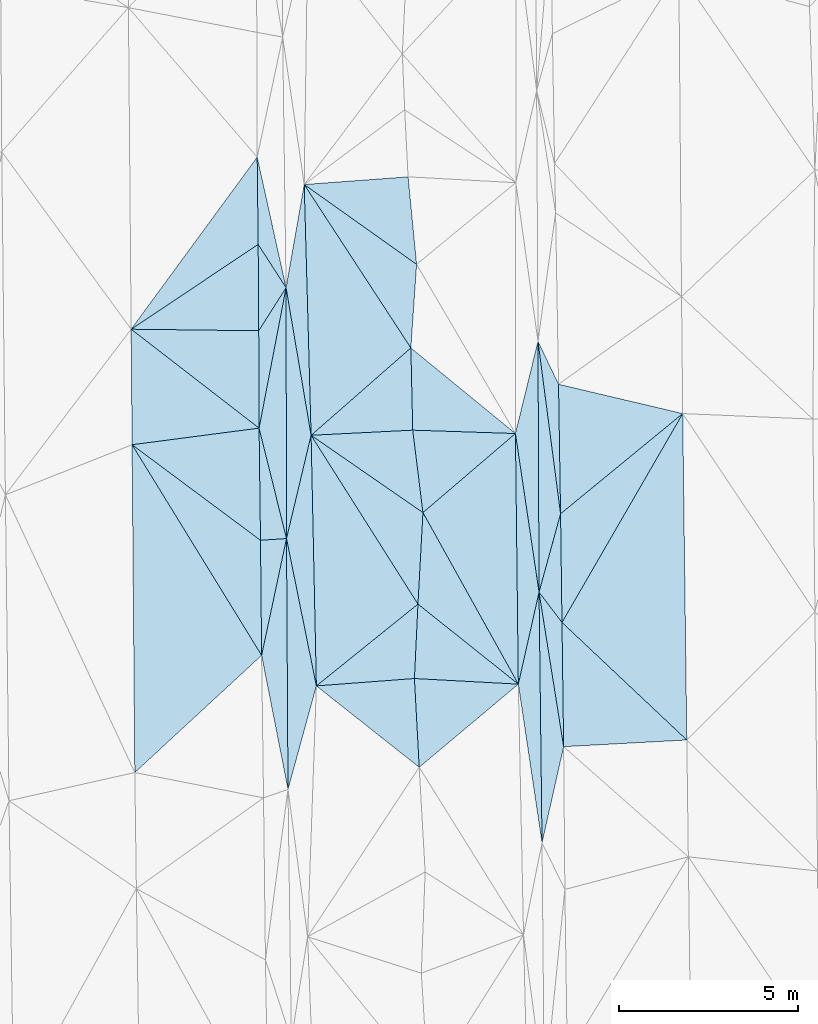
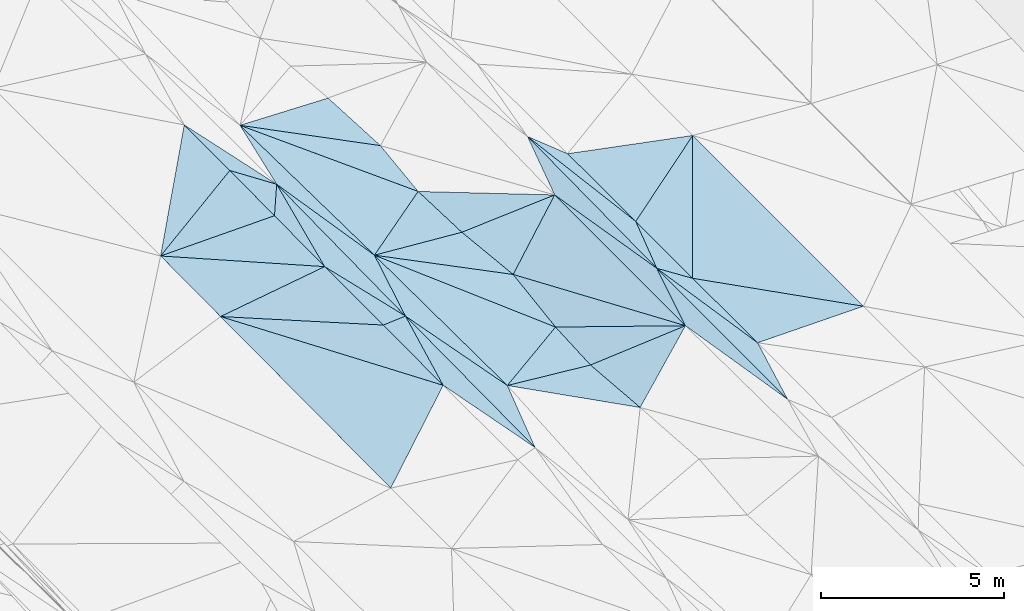
# One storey, part 35 of 275: 45 plates.
"""IFC2X3 building model written with IfcOpenShell, lengths in millimetres."""

import ifcopenshell
import ifcopenshell.guid

model = None  # the IFC model being written
_history = None  # IfcOwnerHistory: only IFC2X3 demands one
_inside = {}  # id of a spatial element -> (the spatial element, [elements in it])
_under = {}  # id of a project, library or spatial element -> (it, [spatial elements below it])
_declared = {}  # id of a project -> (the project, [libraries it declares])
_typed = {}  # id of a type object -> (the type object, [elements of that type])
_made_of = {}  # id of a material, layer set ... -> (it, [elements and type objects made of it])


def new_model(schema):
    """Start an empty IFC model of exactly this schema.

    Asked for "IFC4X3", IfcOpenShell would pick the latest addendum, in which some entities
    have other attributes; the version numbers below select the first issue.
    IFC2X3 requires an IfcOwnerHistory on every rooted entity: one is made here for all.
    """
    global model, _history
    if schema == "IFC4X3":
        model = ifcopenshell.file(schema_version=(4, 3, 0, 0))
    else:
        model = ifcopenshell.file(schema=schema)
    _inside.clear()
    _under.clear()
    _declared.clear()
    _typed.clear()
    _made_of.clear()
    _history = None
    if model.schema == "IFC2X3":
        org = make("IfcOrganization", Name="unknown")
        user = make(
            "IfcPersonAndOrganization",
            ThePerson=make("IfcPerson", FamilyName="unknown"),
            TheOrganization=org,
        )
        app = make(
            "IfcApplication",
            ApplicationDeveloper=org,
            Version="unknown",
            ApplicationFullName="unknown",
            ApplicationIdentifier="unknown",
        )
        _history = make(
            "IfcOwnerHistory",
            OwningUser=user,
            OwningApplication=app,
            ChangeAction="ADDED",
            CreationDate=0,
        )
    return model


def make(cls, **values):
    """One entity of the class cls with the attributes given. An attribute that is None is left unset."""
    return model.create_entity(
        cls, **{name: value for name, value in values.items() if value is not None}
    )


def rooted(cls, **values):
    """An entity with a GlobalId (a new one), such as an element, a storey or a relation."""
    return make(cls, GlobalId=ifcopenshell.guid.new(), OwnerHistory=_history, **values)


def si_unit(unit_type, name, prefix=None):
    """IfcSIUnit, for example si_unit("LENGTHUNIT", "METRE", prefix="MILLI")."""
    return make("IfcSIUnit", UnitType=unit_type, Prefix=prefix, Name=name)


def assignment(units):
    """IfcUnitAssignment: the units of a project."""
    return None if units is None else make("IfcUnitAssignment", Units=units)


def point(xyz):
    """IfcCartesianPoint."""
    return None if xyz is None else make("IfcCartesianPoint", Coordinates=xyz)


def direction(xyz):
    """IfcDirection."""
    return None if xyz is None else make("IfcDirection", DirectionRatios=xyz)


def frame(location, z_axis=None, x_axis=None):
    """IfcAxis2Placement3D, a coordinate frame: its origin and axes. An axis left out is left unset."""
    return make(
        "IfcAxis2Placement3D",
        Location=point(location),
        Axis=direction(z_axis),
        RefDirection=direction(x_axis),
    )


def origin_with_axes():
    """The frame at (0, 0, 0) with the z axis (0, 0, 1) and the x axis (1, 0, 0) written out."""
    return frame((0.0, 0.0, 0.0), z_axis=(0.0, 0.0, 1.0), x_axis=(1.0, 0.0, 0.0))


def place(relative_to, where):
    """IfcLocalPlacement: puts the frame where relative to a parent placement (None: the world)."""
    return make(
        "IfcLocalPlacement", PlacementRelTo=relative_to, RelativePlacement=where
    )


def context(
    kind, dimensions, precision=None, world=None, true_north=None, identifier=None
):
    """IfcGeometricRepresentationContext, for example the 3D "Model" context."""
    return make(
        "IfcGeometricRepresentationContext",
        ContextIdentifier=identifier,
        ContextType=kind,
        CoordinateSpaceDimension=dimensions,
        Precision=precision,
        WorldCoordinateSystem=world,
        TrueNorth=true_north,
    )


def subcontext(parent, identifier, kind, view, scale=None):
    """IfcGeometricRepresentationSubContext, for example "Body" below "Model"."""
    return make(
        "IfcGeometricRepresentationSubContext",
        ContextIdentifier=identifier,
        ContextType=kind,
        ParentContext=parent,
        TargetScale=scale,
        TargetView=view,
    )


def project(units=None, contexts=None):
    """IfcProject with its units and contexts."""
    return rooted(
        "IfcProject",
        Name="project",
        RepresentationContexts=contexts,
        UnitsInContext=assignment(units),
    )


def spatial(cls, under=None, at=None, **own):
    """A site, building, storey or space (cls), placed at a placement, below another one or the project."""
    s = rooted(cls, ObjectPlacement=at, **own)
    if under is not None:
        _under.setdefault(under.id(), (under, []))[1].append(s)
    return s


def polyline(points):
    """IfcPolyline through the points."""
    return make("IfcPolyline", Points=[point(p) for p in points])


def outline(outer, holes=None, kind="AREA"):
    """IfcArbitraryClosedProfileDef: a profile drawn as a closed curve; with holes, ...WithVoids."""
    if holes is None:
        return make("IfcArbitraryClosedProfileDef", ProfileType=kind, OuterCurve=outer)
    return make(
        "IfcArbitraryProfileDefWithVoids",
        ProfileType=kind,
        OuterCurve=outer,
        InnerCurves=holes,
    )


def extrude(swept, where, along, depth):
    """IfcExtrudedAreaSolid: the profile swept, set in the frame where, extruded along a direction by depth."""
    return make(
        "IfcExtrudedAreaSolid",
        SweptArea=swept,
        Position=where,
        ExtrudedDirection=direction(along),
        Depth=depth,
    )


def shape(context_of_items, identifier, shape_type, items):
    """IfcShapeRepresentation: the items that make up one representation, for example the "Body"."""
    return make(
        "IfcShapeRepresentation",
        ContextOfItems=context_of_items,
        RepresentationIdentifier=identifier,
        RepresentationType=shape_type,
        Items=items,
    )


def material(Name=None, Category=None):
    """IfcMaterial."""
    return make("IfcMaterial", Name=Name, Category=Category)


def made_of(thing, what):
    """Note that an element or type object is made of a material, layer set ...; save() writes the relation."""
    if what is not None:
        _made_of.setdefault(what.id(), (what, []))[1].append(thing)
    return thing


def type_object(cls, material=None, **own):
    """A type object (cls), such as IfcWallType, which elements share."""
    return made_of(rooted(cls, **own), material)


def element(
    cls,
    number,
    at=None,
    inside=None,
    cuts=None,
    type_object=None,
    material=None,
    context=None,
    identifier="Body",
    shape_type=None,
    held_by="IfcProductDefinitionShape",
    body=None,
    shapes=None,
    **own,
):
    """One element of the class cls, such as IfcWall. Its Tag is "e" and its number.

    at: its placement. inside: the storey or other place that contains it. cuts: it is an
    opening in that element (IfcRelVoidsElement). A single representation is given by context,
    identifier, shape_type and body (its items); several are given by shapes. held_by: the class
    of the entity that holds the representations. save() writes the other relations.
    """
    e = rooted(cls, Tag="e%d" % number, ObjectPlacement=at, **own)
    if body is not None:
        shapes = [shape(context, identifier, shape_type, body)]
    if shapes is not None:
        e.Representation = make(held_by, Representations=shapes)
    if inside is not None:
        _inside.setdefault(inside.id(), (inside, []))[1].append(e)
    if cuts is not None:
        rooted(
            "IfcRelVoidsElement", RelatingBuildingElement=cuts, RelatedOpeningElement=e
        )
    if type_object is not None:
        _typed.setdefault(type_object.id(), (type_object, []))[1].append(e)
    return made_of(e, material)


def aggregate(whole, parts):
    """IfcRelAggregates: a whole, such as a stair, and the parts it consists of."""
    return rooted("IfcRelAggregates", RelatingObject=whole, RelatedObjects=parts)


def save(model, path):
    """Write the relations noted so far, then the file.

    IfcRelAggregates (storeys below a building ...), IfcRelContainedInSpatialStructure (elements
    in a storey), IfcRelDefinesByType, IfcRelAssociatesMaterial and IfcRelDeclares: one each for
    every whole, place, type object, material and project.
    """
    for whole, parts in _under.values():
        aggregate(whole, parts)
    for where, things in _inside.values():
        rooted(
            "IfcRelContainedInSpatialStructure",
            RelatedElements=things,
            RelatingStructure=where,
        )
    for kind, things in _typed.values():
        rooted("IfcRelDefinesByType", RelatedObjects=things, RelatingType=kind)
    for what, things in _made_of.values():
        rooted("IfcRelAssociatesMaterial", RelatedObjects=things, RelatingMaterial=what)
    for by, libraries in _declared.values():
        rooted("IfcRelDeclares", RelatingContext=by, RelatedDefinitions=libraries)
    model.write(path)


model = new_model("IFC2X3")

# Units and contexts
model_context = context("Model", 3, precision=1e-05, world=origin_with_axes())
body_context = subcontext(model_context, "Body", "Model", "MODEL_VIEW")
ifc_project = project(units=[si_unit("LENGTHUNIT", "METRE", prefix="MILLI"), si_unit("AREAUNIT", "SQUARE_METRE"), si_unit("VOLUMEUNIT", "CUBIC_METRE"), si_unit("MASSUNIT", "GRAM", prefix="KILO"), si_unit("TIMEUNIT", "SECOND"), si_unit("PLANEANGLEUNIT", "RADIAN"), si_unit("SOLIDANGLEUNIT", "STERADIAN"), si_unit("THERMODYNAMICTEMPERATUREUNIT", "DEGREE_CELSIUS"), si_unit("LUMINOUSINTENSITYUNIT", "LUMEN")], contexts=[model_context])

# Site, building, storey
site_placement = place(None, origin_with_axes())
site = spatial("IfcSite", under=ifc_project, at=site_placement, CompositionType="ELEMENT")
building_placement = place(site_placement, origin_with_axes())
building = spatial("IfcBuilding", under=site, at=building_placement, Name="Undefined", CompositionType="ELEMENT")
storey_placement = place(building_placement, origin_with_axes())
storey = spatial("IfcBuildingStorey", under=building, at=storey_placement, Name="Undefined", CompositionType="ELEMENT", Elevation=0.0)

# Plates
ifc_material = material()
plate_type_1 = type_object("IfcPlateType", PredefinedType="NOTDEFINED")
plate_1_placement = place(storey_placement, frame((-83577.8954282212, 28888.7044978284, 41809.500438264), z_axis=(0.0365790890589435, 0.0219837496908715, -0.999088927469996), x_axis=(-0.00810992466042076, 0.999731612560137, 0.0217009670270915)))
element("IfcPlate", 1, at=plate_1_placement, inside=storey, type_object=plate_type_1, material=ifc_material, Name="00", context=body_context, shape_type="SweptSolid", body=[
    extrude(outline(polyline([(0.0, 0.0), (3225.66284179688, -7.8580342233181e-10), (437.305480957031, 3551.52978515625), (0.0, 0.0)])), frame((-8.85201319254618e-08, 2.18876761149539e-07, -0.5000001331573), z_axis=(0.0, 0.0, 1.0), x_axis=(1.0, 0.0, 0.0)), (0.0, 0.0, 1.0), 1.0),
])
plate_type_2 = type_object("IfcPlateType", PredefinedType="NOTDEFINED")
plate_2_placement = place(storey_placement, frame((-71531.1187401543, 20460.0011105152, 41829.5001680198), z_axis=(-0.0158859229955657, 0.0218092317217035, -0.999635931158083), x_axis=(-0.219018831395794, -0.975558195381278, -0.0178033400923545)))
element("IfcPlate", 2, at=plate_2_placement, inside=storey, type_object=plate_type_2, material=ifc_material, Name="00", context=body_context, shape_type="SweptSolid", body=[
    extrude(outline(polyline([(0.0, 0.0), (2752.29248046875, -6.37373887002468e-09), (-4058.8349609375, 1614.81384277344), (0.0, 0.0)])), frame((-8.85201319254618e-08, 2.18876761149539e-07, -0.5000001331573), z_axis=(0.0, 0.0, 1.0), x_axis=(1.0, 0.0, 0.0)), (0.0, 0.0, 1.0), 1.0),
])
plate_type_3 = type_object("IfcPlateType", PredefinedType="NOTDEFINED")
plate_3_placement = place(storey_placement, frame((-72217.5719747491, 24772.717407491, 41934.5006367606), z_axis=(-0.0482096767140328, 0.0166415767088893, -0.998698595671272), x_axis=(0.603394067693805, -0.796315346795605, -0.0423965509177359)))
element("IfcPlate", 3, at=plate_3_placement, inside=storey, type_object=plate_type_3, material=ifc_material, Name="00", context=body_context, shape_type="SweptSolid", body=[
    extrude(outline(polyline([(0.0, 0.0), (1061.40710449219, -2.30647856369615e-09), (3852.92797851563, 2058.32739257813), (0.0, 0.0)])), frame((-8.85201319254618e-08, 2.18876761149539e-07, -0.5000001331573), z_axis=(0.0, 0.0, 1.0), x_axis=(1.0, 0.0, 0.0)), (0.0, 0.0, 1.0), 1.0),
])
plate_4_placement = place(storey_placement, frame((-80085.5849594555, 36916.2971563782, 42099.5003578976), z_axis=(0.0323594222888337, 0.0208706576789451, -0.999258366708621), x_axis=(0.216025640668646, -0.976295798259957, -0.0133954049455226)))
element("IfcPlate", 4, at=plate_4_placement, inside=storey, type_object=plate_type_3, material=ifc_material, Name="00", context=body_context, shape_type="SweptSolid", body=[
    extrude(outline(polyline([(0.0, 0.0), (3732.62329101563, 1.23254721984267e-08), (2385.78051757813, 499.751312255859), (0.0, 0.0)])), frame((-8.85201319254618e-08, 2.18876761149539e-07, -0.5000001331573), z_axis=(0.0, 0.0, 1.0), x_axis=(1.0, 0.0, 0.0)), (0.0, 0.0, 1.0), 1.0),
])
plate_type_4 = type_object("IfcPlateType", PredefinedType="NOTDEFINED")
plate_5_placement = place(storey_placement, frame((-75562.7001384083, 19884.6849697928, 41435.504392064), z_axis=(0.132110338187401, -0.00929839405583627, -0.991191403520023), x_axis=(-0.0536836325164533, 0.998421309205957, -0.0165214080302371)))
element("IfcPlate", 5, at=plate_5_placement, inside=storey, type_object=plate_type_4, material=ifc_material, Name="00", context=body_context, shape_type="SweptSolid", body=[
    extrude(outline(polyline([(0.0, 0.0), (2481.62866210938, 1.71712599694729e-09), (2163.00415039063, 2912.6962890625), (0.0, 0.0)])), frame((-8.85201319254618e-08, 2.18876761149539e-07, -0.5000001331573), z_axis=(0.0, 0.0, 1.0), x_axis=(1.0, 0.0, 0.0)), (0.0, 0.0, 1.0), 1.0),
])
plate_type_5 = type_object("IfcPlateType", PredefinedType="NOTDEFINED")
plate_6_placement = place(storey_placement, frame((-78580.5815478131, 29151.8177160993, 41943.5003782891), z_axis=(-0.0342257553858647, 0.0199021579772941, -0.999215943515772), x_axis=(-0.167131835422519, 0.985608457515903, 0.0253558289436967)))
element("IfcPlate", 6, at=plate_6_placement, inside=storey, type_object=plate_type_5, material=ifc_material, Name="00", context=body_context, shape_type="SweptSolid", body=[
    extrude(outline(polyline([(0.0, 0.0), (4180.49853515625, 1.17870513349772e-09), (6935.2119140625, 981.620422363281), (0.0, 0.0)])), frame((-8.85201319254618e-08, 2.18876761149539e-07, -0.5000001331573), z_axis=(0.0, 0.0, 1.0), x_axis=(1.0, 0.0, 0.0)), (0.0, 0.0, 1.0), 1.0),
])
plate_type_6 = type_object("IfcPlateType", PredefinedType="NOTDEFINED")
plate_7_placement = place(storey_placement, frame((-71577.1213630307, 23927.5055979351, 41889.500522527), z_axis=(-0.0404609860858899, 0.0225251823164607, -0.998927186919331), x_axis=(-0.603394067694056, 0.796315346795313, 0.0423965509196396)))
element("IfcPlate", 7, at=plate_7_placement, inside=storey, type_object=plate_type_6, material=ifc_material, Name="00", context=body_context, shape_type="SweptSolid", body=[
    extrude(outline(polyline([(0.0, 0.0), (1061.40710449219, -2.30647856369615e-09), (2442.107421875, 1800.33654785156), (0.0, 0.0)])), frame((-8.85201319254618e-08, 2.18876761149539e-07, -0.5000001331573), z_axis=(0.0, 0.0, 1.0), x_axis=(1.0, 0.0, 0.0)), (0.0, 0.0, 1.0), 1.0),
])
plate_type_7 = type_object("IfcPlateType", PredefinedType="NOTDEFINED")
plate_8_placement = place(storey_placement, frame((-72133.8372456878, 17774.9804902731, 41780.5061622233), z_axis=(0.154865689625418, 0.0235862732524632, -0.987653940351024), x_axis=(-0.147781994493307, 0.989019859654668, 0.000446443994690539)))
element("IfcPlate", 8, at=plate_8_placement, inside=storey, type_object=plate_type_7, material=ifc_material, Name="00", context=body_context, shape_type="SweptSolid", body=[
    extrude(outline(polyline([(0.0, 0.0), (4479.84375, -1.80443748831749e-09), (6933.33251953125, 963.318359375), (0.0, 0.0)])), frame((-8.85201319254618e-08, 2.18876761149539e-07, -0.5000001331573), z_axis=(0.0, 0.0, 1.0), x_axis=(1.0, 0.0, 0.0)), (0.0, 0.0, 1.0), 1.0),
])
plate_type_8 = type_object("IfcPlateType", PredefinedType="NOTDEFINED")
plate_9_placement = place(storey_placement, frame((-79267.0023264484, 26270.1866442393, 41903.5002109373), z_axis=(0.0210886324442645, 0.0212531393541428, -0.99955168633204), x_axis=(0.00596718250962067, -0.999758894006023, -0.0211316489832462)))
element("IfcPlate", 9, at=plate_9_placement, inside=storey, type_object=plate_type_8, material=ifc_material, Name="00", context=body_context, shape_type="SweptSolid", body=[
    extrude(outline(polyline([(0.0, 0.0), (7003.712890625, 9.35688149183989e-09), (3258.19970703125, 714.219848632813), (0.0, 0.0)])), frame((-8.85201319254618e-08, 2.18876761149539e-07, -0.5000001331573), z_axis=(0.0, 0.0, 1.0), x_axis=(1.0, 0.0, 0.0)), (0.0, 0.0, 1.0), 1.0),
])
plate_type_9 = type_object("IfcPlateType", PredefinedType="NOTDEFINED")
plate_10_placement = place(storey_placement, frame((-80032.4151554548, 29351.8484999908, 41949.5001585233), z_axis=(0.017952224590618, 0.0193806995829433, -0.999650992154724), x_axis=(0.241026704624038, -0.970410378708532, -0.0144853219791851)))
element("IfcPlate", 10, at=plate_10_placement, inside=storey, type_object=plate_type_9, material=ifc_material, Name="00", context=body_context, shape_type="SweptSolid", body=[
    extrude(outline(polyline([(0.0, 0.0), (3175.62841796875, 2.75031197816134e-09), (3049.15405273438, 716.631164550781), (0.0, 0.0)])), frame((-8.85201319254618e-08, 2.18876761149539e-07, -0.5000001331573), z_axis=(0.0, 0.0, 1.0), x_axis=(1.0, 0.0, 0.0)), (0.0, 0.0, 1.0), 1.0),
])
plate_type_10 = type_object("IfcPlateType", PredefinedType="NOTDEFINED")
plate_11_placement = place(storey_placement, frame((-79961.6099776215, 23008.8310598778, 41819.500183161), z_axis=(0.0177744628841501, 0.021960259549505, -0.999600828065733), x_axis=(-0.00973145466687775, 0.999715212632475, 0.021789732014688)))
element("IfcPlate", 11, at=plate_11_placement, inside=storey, type_object=plate_type_10, material=ifc_material, Name="00", context=body_context, shape_type="SweptSolid", body=[
    extrude(outline(polyline([(0.0, 0.0), (3212.5224609375, -5.29689714312553e-09), (3255.498046875, 726.435913085938), (0.0, 0.0)])), frame((-8.85201319254618e-08, 2.18876761149539e-07, -0.5000001331573), z_axis=(0.0, 0.0, 1.0), x_axis=(1.0, 0.0, 0.0)), (0.0, 0.0, 1.0), 1.0),
])
plate_type_11 = type_object("IfcPlateType", PredefinedType="NOTDEFINED")
plate_12_placement = place(storey_placement, frame((-83604.0566548315, 32113.4997537222, 41879.500356108), z_axis=(0.0338923577972761, 0.0185048063500158, -0.999254161975265), x_axis=(0.99935833277254, -0.0122179643277402, 0.0336696312093747)))
element("IfcPlate", 12, at=plate_12_placement, inside=storey, type_object=plate_type_11, material=ifc_material, Name="00", context=body_context, shape_type="SweptSolid", body=[
    extrude(outline(polyline([(0.0, 0.0), (3564.04272460938, -1.49520928971469e-09), (3605.45629882813, 2718.26879882813), (0.0, 0.0)])), frame((-8.85201319254618e-08, 2.18876761149539e-07, -0.5000001331573), z_axis=(0.0, 0.0, 1.0), x_axis=(1.0, 0.0, 0.0)), (0.0, 0.0, 1.0), 1.0),
])
plate_type_12 = type_object("IfcPlateType", PredefinedType="NOTDEFINED")
plate_13_placement = place(storey_placement, frame((-79279.2467850487, 33272.1526790614, 42049.5002376352), z_axis=(0.024009036176491, 0.0208827174070778, -0.999493610932842), x_axis=(0.0017485426791587, -0.9997811544217, -0.0208467230449063)))
element("IfcPlate", 13, at=plate_13_placement, inside=storey, type_object=plate_type_12, material=ifc_material, Name="00", context=body_context, shape_type="SweptSolid", body=[
    extrude(outline(polyline([(0.0, 0.0), (7003.4990234375, 1.4202669262886e-08), (3920.21313476563, 760.240295410156), (0.0, 0.0)])), frame((-8.85201319254618e-08, 2.18876761149539e-07, -0.5000001331573), z_axis=(0.0, 0.0, 1.0), x_axis=(1.0, 0.0, 0.0)), (0.0, 0.0, 1.0), 1.0),
])
plate_type_13 = type_object("IfcPlateType", PredefinedType="NOTDEFINED")
plate_14_placement = place(storey_placement, frame((-72246.7669825455, 31775.9377631162, 42087.500477087), z_axis=(-0.0386779432648295, 0.0214953328991954, -0.999020503977949), x_axis=(0.430716952695254, -0.901765634886737, -0.0360783369660324)))
element("IfcPlate", 14, at=plate_14_placement, inside=storey, type_object=plate_type_13, material=ifc_material, Name="00", context=body_context, shape_type="SweptSolid", body=[
    extrude(outline(polyline([(0.0, 0.0), (1330.43823242188, -1.54250301420689e-09), (4618.392578125, 1507.56677246094), (0.0, 0.0)])), frame((-8.85201319254618e-08, 2.18876761149539e-07, -0.5000001331573), z_axis=(0.0, 0.0, 1.0), x_axis=(1.0, 0.0, 0.0)), (0.0, 0.0, 1.0), 1.0),
])
plate_type_14 = type_object("IfcPlateType", PredefinedType="NOTDEFINED")
plate_15_placement = place(storey_placement, frame((-72876.4945764287, 29201.4263012232, 41922.5026315636), z_axis=(0.102570962510399, -0.00416192529065004, -0.994716982878831), x_axis=(-0.994184557459251, 0.0325511904875885, -0.102652256221647)))
element("IfcPlate", 15, at=plate_15_placement, inside=storey, type_object=plate_type_14, material=ifc_material, Name="00", context=body_context, shape_type="SweptSolid", body=[
    extrude(outline(polyline([(0.0, 0.0), (2883.52172851563, -1.81025825440884e-08), (3011.80932617188, 2291.84790039063), (0.0, 0.0)])), frame((-8.85201319254618e-08, 2.18876761149539e-07, -0.5000001331573), z_axis=(0.0, 0.0, 1.0), x_axis=(1.0, 0.0, 0.0)), (0.0, 0.0, 1.0), 1.0),
])
plate_type_15 = type_object("IfcPlateType", PredefinedType="NOTDEFINED")
plate_16_placement = place(storey_placement, frame((-71616.8559165438, 26960.4280257228, 41959.5004527842), z_axis=(-0.0373444008892423, 0.0216710195204286, -0.99906744648956), x_axis=(-0.264767843340425, -0.964249227132675, -0.0110189430935287)))
element("IfcPlate", 16, at=plate_16_placement, inside=storey, type_object=plate_type_15, material=ifc_material, Name="00", context=body_context, shape_type="SweptSolid", body=[
    extrude(outline(polyline([(0.0, 0.0), (2268.82006835938, 2.69210431724787e-09), (-4477.98193359375, 1884.13977050781), (0.0, 0.0)])), frame((-8.85201319254618e-08, 2.18876761149539e-07, -0.5000001331573), z_axis=(0.0, 0.0, 1.0), x_axis=(1.0, 0.0, 0.0)), (0.0, 0.0, 1.0), 1.0),
])
plate_type_16 = type_object("IfcPlateType", PredefinedType="NOTDEFINED")
plate_17_placement = place(storey_placement, frame((-72217.464187417, 24772.7201979441, 41934.5071666719), z_axis=(0.167350880958245, 0.0222312881205072, -0.985646717881718), x_axis=(-0.14718000651663, 0.989106092849445, -0.00268006900463302)))
element("IfcPlate", 17, at=plate_17_placement, inside=storey, type_object=plate_type_16, material=ifc_material, Name="00", context=body_context, shape_type="SweptSolid", body=[
    extrude(outline(polyline([(0.0, 0.0), (4477.49658203125, 1.25510268844664e-08), (6930.81298828125, 1016.44128417969), (0.0, 0.0)])), frame((-8.85201319254618e-08, 2.18876761149539e-07, -0.5000001331573), z_axis=(0.0, 0.0, 1.0), x_axis=(1.0, 0.0, 0.0)), (0.0, 0.0, 1.0), 1.0),
])
plate_type_17 = type_object("IfcPlateType", PredefinedType="NOTDEFINED")
plate_18_placement = place(storey_placement, frame((-75635.7783292132, 33924.0666689191, 41665.503397373), z_axis=(-0.112457328286654, 0.0306847070555357, -0.993182660978102), x_axis=(-0.0683444214472427, -0.997394869857768, -0.0230762570285459)))
element("IfcPlate", 18, at=plate_18_placement, inside=storey, type_object=plate_type_17, material=ifc_material, Name="00", context=body_context, shape_type="SweptSolid", body=[
    extrude(outline(polyline([(0.0, 0.0), (2340.06762695313, 4.75847627967596e-09), (-2017.546875, 3303.32275390625), (0.0, 0.0)])), frame((-8.85201319254618e-08, 2.18876761149539e-07, -0.5000001331573), z_axis=(0.0, 0.0, 1.0), x_axis=(1.0, 0.0, 0.0)), (0.0, 0.0, 1.0), 1.0),
])
plate_type_18 = type_object("IfcPlateType", PredefinedType="NOTDEFINED")
plate_19_placement = place(storey_placement, frame((-80057.8781180073, 34479.4073045826, 42049.5003575438), z_axis=(0.0324763303268787, 0.0209460588232763, -0.999252996286862), x_axis=(0.542009704340946, -0.840372227289932, 9.23567735952663e-11)))
element("IfcPlate", 19, at=plate_19_placement, inside=storey, type_object=plate_type_18, material=ifc_material, Name="00", context=body_context, shape_type="SweptSolid", body=[
    extrude(outline(polyline([(0.0, 0.0), (1436.5712890625, 1.86992110684514e-09), (2033.27893066406, 1293.82263183594), (0.0, 0.0)])), frame((-8.85201319254618e-08, 2.18876761149539e-07, -0.5000001331573), z_axis=(0.0, 0.0, 1.0), x_axis=(1.0, 0.0, 0.0)), (0.0, 0.0, 1.0), 1.0),
])
plate_type_19 = type_object("IfcPlateType", PredefinedType="NOTDEFINED")
plate_20_placement = place(storey_placement, frame((-72795.8891888198, 22205.6126191351, 41782.5044409164), z_axis=(0.131463873618774, -0.0210253098088936, -0.991097970071873), x_axis=(-0.989748465184462, 0.0535063504847322, -0.132419961194707)))
element("IfcPlate", 20, at=plate_20_placement, inside=storey, type_object=plate_type_19, material=ifc_material, Name="00", context=body_context, shape_type="SweptSolid", body=[
    extrude(outline(polyline([(0.0, 0.0), (2930.07177734375, 1.47738319355994e-08), (2947.82495117188, 2079.69848632813), (0.0, 0.0)])), frame((-8.85201319254618e-08, 2.18876761149539e-07, -0.5000001331573), z_axis=(0.0, 0.0, 1.0), x_axis=(1.0, 0.0, 0.0)), (0.0, 0.0, 1.0), 1.0),
])
plate_type_20 = type_object("IfcPlateType", PredefinedType="NOTDEFINED")
plate_21_placement = place(storey_placement, frame((-75795.7079537254, 31590.0754747501, 41611.5030759752), z_axis=(-0.110581393133359, -0.00901903351793664, -0.993826148039529), x_axis=(0.022807924556756, -0.999718508472323, 0.00653470697793369)))
element("IfcPlate", 21, at=plate_21_placement, inside=storey, type_object=plate_type_20, material=ifc_material, Name="00", context=body_context, shape_type="SweptSolid", body=[
    extrude(outline(polyline([(0.0, 0.0), (2295.43579101563, 9.74978320300579e-10), (2376.2373046875, 2857.380859375), (0.0, 0.0)])), frame((-8.85201319254618e-08, 2.18876761149539e-07, -0.5000001331573), z_axis=(0.0, 0.0, 1.0), x_axis=(1.0, 0.0, 0.0)), (0.0, 0.0, 1.0), 1.0),
])
plate_type_21 = type_object("IfcPlateType", PredefinedType="NOTDEFINED")
plate_22_placement = place(storey_placement, frame((-83501.4330039712, 19738.2366394495, 41619.5004359651), z_axis=(0.036995731903874, 0.0210542867858377, -0.999093605639049), x_axis=(-0.00835400766863591, 0.999749610705681, 0.0207587680200689)))
element("IfcPlate", 22, at=plate_22_placement, inside=storey, type_object=plate_type_21, material=ifc_material, Name="00", context=body_context, shape_type="SweptSolid", body=[
    extrude(outline(polyline([(0.0, 0.0), (9152.7587890625, -3.49245965480804e-10), (3244.35498046875, 3569.50415039063), (0.0, 0.0)])), frame((-8.85201319254618e-08, 2.18876761149539e-07, -0.5000001331573), z_axis=(0.0, 0.0, 1.0), x_axis=(1.0, 0.0, 0.0)), (0.0, 0.0, 1.0), 1.0),
])
plate_type_22 = type_object("IfcPlateType", PredefinedType="NOTDEFINED")
plate_23_placement = place(storey_placement, frame((-78433.2792006997, 22155.9833566374, 41795.5002887074), z_axis=(-0.0280403093256503, 0.020552260115446, -0.999395490112432), x_axis=(-0.198548136536098, 0.97975362614654, 0.0257190499581173)))
element("IfcPlate", 23, at=plate_23_placement, inside=storey, type_object=plate_type_22, material=ifc_material, Name="00", context=body_context, shape_type="SweptSolid", body=[
    extrude(outline(polyline([(0.0, 0.0), (4199.22216796875, -7.8580342233181e-10), (6887.24658203125, 1245.44580078125), (0.0, 0.0)])), frame((-8.85201319254618e-08, 2.18876761149539e-07, -0.5000001331573), z_axis=(0.0, 0.0, 1.0), x_axis=(1.0, 0.0, 0.0)), (0.0, 0.0, 1.0), 1.0),
])
plate_type_23 = type_object("IfcPlateType", PredefinedType="NOTDEFINED")
plate_24_placement = place(storey_placement, frame((-75597.5556399421, 24439.6054823092, 41363.5052420851), z_axis=(-0.144359484290172, -0.00792124908117107, -0.989493604379771), x_axis=(-0.0473635874637829, -0.998766498099774, 0.0149054639671231)))
element("IfcPlate", 24, at=plate_24_placement, inside=storey, type_object=plate_type_23, material=ifc_material, Name="00", context=body_context, shape_type="SweptSolid", body=[
    extrude(outline(polyline([(0.0, 0.0), (2079.77416992188, 1.45519152283669e-11), (2421.57153320313, 2753.04711914063), (0.0, 0.0)])), frame((-8.85201319254618e-08, 2.18876761149539e-07, -0.5000001331573), z_axis=(0.0, 0.0, 1.0), x_axis=(1.0, 0.0, 0.0)), (0.0, 0.0, 1.0), 1.0),
])
plate_type_24 = type_object("IfcPlateType", PredefinedType="NOTDEFINED")
plate_25_placement = place(storey_placement, frame((-72795.8619816203, 22205.6476534948, 41782.5093160163), z_axis=(0.185882182437119, 0.049046756385946, -0.981347150574368), x_axis=(-0.776561760453903, 0.619243502691278, -0.116143517147417)))
element("IfcPlate", 25, at=plate_25_placement, inside=storey, type_object=plate_type_24, material=ifc_material, Name="00", context=body_context, shape_type="SweptSolid", body=[
    extrude(outline(polyline([(0.0, 0.0), (3607.60546875, 3.22324922308326e-09), (5063.505859375, 2109.044921875), (0.0, 0.0)])), frame((-8.85201319254618e-08, 2.18876761149539e-07, -0.5000001331573), z_axis=(0.0, 0.0, 1.0), x_axis=(1.0, 0.0, 0.0)), (0.0, 0.0, 1.0), 1.0),
])
plate_type_25 = type_object("IfcPlateType", PredefinedType="NOTDEFINED")
plate_26_placement = place(storey_placement, frame((-80032.4059777676, 29351.8480658986, 41949.5003993456), z_axis=(0.0363056497551186, 0.018512028161076, -0.999169257237843), x_axis=(-0.00363930267338883, 0.999824230819109, 0.0183919260282667)))
element("IfcPlate", 26, at=plate_26_placement, inside=storey, type_object=plate_type_25, material=ifc_material, Name="00", context=body_context, shape_type="SweptSolid", body=[
    extrude(outline(polyline([(0.0, 0.0), (2718.58422851563, -2.05182004719973e-09), (3918.71264648438, 767.938110351563), (0.0, 0.0)])), frame((-8.85201319254618e-08, 2.18876761149539e-07, -0.5000001331573), z_axis=(0.0, 0.0, 1.0), x_axis=(1.0, 0.0, 0.0)), (0.0, 0.0, 1.0), 1.0),
])
plate_type_26 = type_object("IfcPlateType", PredefinedType="NOTDEFINED")
plate_27_placement = place(storey_placement, frame((-79267.0273770819, 26270.186401419, 41903.5003067834), z_axis=(-0.0290285809486196, 0.0207872229141716, -0.999362413167328), x_axis=(-0.00174854253858263, 0.999781154422318, 0.0208467230270944)))
element("IfcPlate", 27, at=plate_27_placement, inside=storey, type_object=plate_type_26, material=ifc_material, Name="00", context=body_context, shape_type="SweptSolid", body=[
    extrude(outline(polyline([(0.0, 0.0), (7003.4990234375, 1.4202669262886e-08), (2880.634765625, 691.777954101563), (0.0, 0.0)])), frame((-8.85201319254618e-08, 2.18876761149539e-07, -0.5000001331573), z_axis=(0.0, 0.0, 1.0), x_axis=(1.0, 0.0, 0.0)), (0.0, 0.0, 1.0), 1.0),
])
plate_type_27 = type_object("IfcPlateType", PredefinedType="NOTDEFINED")
plate_28_placement = place(storey_placement, frame((-78433.3367387347, 22155.9610373649, 41795.5052828451), z_axis=(-0.143129721348599, -0.0240681858972353, -0.989411241746468), x_axis=(0.986696142981387, 0.0744101865396399, -0.144547035821526)))
element("IfcPlate", 28, at=plate_28_placement, inside=storey, type_object=plate_type_27, material=ifc_material, Name="00", context=body_context, shape_type="SweptSolid", body=[
    extrude(outline(polyline([(0.0, 0.0), (2774.18359375, -2.80124368146062e-10), (2715.34057617188, 2480.93090820313), (0.0, 0.0)])), frame((-8.85201319254618e-08, 2.18876761149539e-07, -0.5000001331573), z_axis=(0.0, 0.0, 1.0), x_axis=(1.0, 0.0, 0.0)), (0.0, 0.0, 1.0), 1.0),
])
plate_type_28 = type_object("IfcPlateType", PredefinedType="NOTDEFINED")
plate_29_placement = place(storey_placement, frame((-72795.8863969605, 22205.6338286552, 41782.5048228596), z_axis=(0.137050682689416, 0.0213973443521721, -0.990332905658011), x_axis=(-0.48539688721219, 0.872958080280942, -0.0483120270422356)))
element("IfcPlate", 29, at=plate_29_placement, inside=storey, type_object=plate_type_28, material=ifc_material, Name="00", context=body_context, shape_type="SweptSolid", body=[
    extrude(outline(polyline([(0.0, 0.0), (5485.1767578125, -2.70738382823765e-08), (6139.3994140625, 3357.85034179688), (0.0, 0.0)])), frame((-8.85201319254618e-08, 2.18876761149539e-07, -0.5000001331573), z_axis=(0.0, 0.0, 1.0), x_axis=(1.0, 0.0, 0.0)), (0.0, 0.0, 1.0), 1.0),
])
plate_type_29 = type_object("IfcPlateType", PredefinedType="NOTDEFINED")
plate_30_placement = place(storey_placement, frame((-71577.1161224632, 23927.5027835036, 41889.5002823773), z_axis=(-0.0299814209296456, 0.0168956118731587, -0.999407650910514), x_axis=(0.727587665545043, -0.685200633586407, -0.033410786873426)))
element("IfcPlate", 30, at=plate_30_placement, inside=storey, type_object=plate_type_29, material=ifc_material, Name="00", context=body_context, shape_type="SweptSolid", body=[
    extrude(outline(polyline([(0.0, 0.0), (4788.87255859375, 1.73386069945991e-08), (2411.40258789063, 2492.87719726563), (0.0, 0.0)])), frame((-8.85201319254618e-08, 2.18876761149539e-07, -0.5000001331573), z_axis=(0.0, 0.0, 1.0), x_axis=(1.0, 0.0, 0.0)), (0.0, 0.0, 1.0), 1.0),
])
plate_type_30 = type_object("IfcPlateType", PredefinedType="NOTDEFINED")
plate_31_placement = place(storey_placement, frame((-83577.8943297311, 28888.7045821241, 41809.5004819849), z_axis=(0.0387797780381609, 0.0221516820758004, -0.999002218113916), x_axis=(0.802068829220151, -0.596963356334295, 0.0178981671550465)))
element("IfcPlate", 31, at=plate_31_placement, inside=storey, type_object=plate_type_30, material=ifc_material, Name="00", context=body_context, shape_type="SweptSolid", body=[
    extrude(outline(polyline([(0.0, 0.0), (4469.7314453125, -2.07546690944582e-08), (6410.76513671875, 2559.82177734375), (0.0, 0.0)])), frame((-8.85201319254618e-08, 2.18876761149539e-07, -0.5000001331573), z_axis=(0.0, 0.0, 1.0), x_axis=(1.0, 0.0, 0.0)), (0.0, 0.0, 1.0), 1.0),
])
plate_type_31 = type_object("IfcPlateType", PredefinedType="NOTDEFINED")
plate_32_placement = place(storey_placement, frame((-83604.056618184, 32113.500945245, 41879.5003809548), z_axis=(0.0339650614586969, 0.0208878119134567, -0.999204720722223), x_axis=(0.590569722427062, 0.806141319366464, 0.0369266321578265)))
element("IfcPlate", 32, at=plate_32_placement, inside=storey, type_object=plate_type_31, material=ifc_material, Name="00", context=body_context, shape_type="SweptSolid", body=[
    extrude(outline(polyline([(0.0, 0.0), (5957.759765625, 3.53611540049315e-09), (4007.79858398438, 1462.65222167969), (0.0, 0.0)])), frame((-8.85201319254618e-08, 2.18876761149539e-07, -0.5000001331573), z_axis=(0.0, 0.0, 1.0), x_axis=(1.0, 0.0, 0.0)), (0.0, 0.0, 1.0), 1.0),
])
plate_type_32 = type_object("IfcPlateType", PredefinedType="NOTDEFINED")
plate_33_placement = place(storey_placement, frame((-71673.7186208552, 30576.1943489113, 42039.5002810265), z_axis=(-0.0265914777942254, 0.021694065380498, -0.999410956932125), x_axis=(0.972806350829831, -0.22955405227082, -0.0308665007928159)))
element("IfcPlate", 33, at=plate_33_placement, inside=storey, type_object=plate_type_32, material=ifc_material, Name="00", context=body_context, shape_type="SweptSolid", body=[
    extrude(outline(polyline([(0.0, 0.0), (3563.73388671875, -8.58562998473644e-09), (887.804748535156, 3506.45166015625), (0.0, 0.0)])), frame((-8.85201319254618e-08, 2.18876761149539e-07, -0.5000001331573), z_axis=(0.0, 0.0, 1.0), x_axis=(1.0, 0.0, 0.0)), (0.0, 0.0, 1.0), 1.0),
])
plate_type_33 = type_object("IfcPlateType", PredefinedType="NOTDEFINED")
plate_34_placement = place(storey_placement, frame((-68206.8950282, 29758.1247304979, 41929.5002674064), z_axis=(-0.0255364781706063, 0.0216171064151443, -0.999440137773583), x_axis=(0.0125186366783319, -0.999680861442136, -0.0219421740496556)))
element("IfcPlate", 34, at=plate_34_placement, inside=storey, type_object=plate_type_33, material=ifc_material, Name="00", context=body_context, shape_type="SweptSolid", body=[
    extrude(outline(polyline([(0.0, 0.0), (9114.8671875, -1.19180185720325e-08), (5787.44580078125, 3444.06298828125), (0.0, 0.0)])), frame((-8.85201319254618e-08, 2.18876761149539e-07, -0.5000001331573), z_axis=(0.0, 0.0, 1.0), x_axis=(1.0, 0.0, 0.0)), (0.0, 0.0, 1.0), 1.0),
])
plate_type_34 = type_object("IfcPlateType", PredefinedType="NOTDEFINED")
plate_35_placement = place(storey_placement, frame((-72795.873295031, 22205.6339390767, 41782.5068153645), z_axis=(0.163251664577266, 0.021619421244637, -0.98634755265971), x_axis=(-0.0115168245447955, 0.999733512665803, 0.0200066590238994)))
element("IfcPlate", 35, at=plate_35_placement, inside=storey, type_object=plate_type_34, material=ifc_material, Name="00", context=body_context, shape_type="SweptSolid", body=[
    extrude(outline(polyline([(0.0, 0.0), (6997.669921875, -1.17361196316779e-08), (2562.78149414063, 616.230651855469), (0.0, 0.0)])), frame((-8.85201319254618e-08, 2.18876761149539e-07, -0.5000001331573), z_axis=(0.0, 0.0, 1.0), x_axis=(1.0, 0.0, 0.0)), (0.0, 0.0, 1.0), 1.0),
])
plate_type_35 = type_object("IfcPlateType", PredefinedType="NOTDEFINED")
plate_36_placement = place(storey_placement, frame((-71577.1148396272, 23927.5056828936, 41889.5003068887), z_axis=(-0.0274214476909127, 0.0227061505971568, -0.999366046517288), x_axis=(-0.0130969785391728, 0.999648015814008, 0.0230719230291)))
element("IfcPlate", 36, at=plate_36_placement, inside=storey, type_object=plate_type_35, material=ifc_material, Name="00", context=body_context, shape_type="SweptSolid", body=[
    extrude(outline(polyline([(0.0, 0.0), (3033.99072265625, 4.05998434871435e-09), (5785.3505859375, 3447.58178710938), (0.0, 0.0)])), frame((-8.85201319254618e-08, 2.18876761149539e-07, -0.5000001331573), z_axis=(0.0, 0.0, 1.0), x_axis=(1.0, 0.0, 0.0)), (0.0, 0.0, 1.0), 1.0),
])
plate_type_36 = type_object("IfcPlateType", PredefinedType="NOTDEFINED")
plate_37_placement = place(storey_placement, frame((-75458.4879362858, 26993.9847673875, 41517.5031095685), z_axis=(-0.090770066169837, 0.0648540441930948, -0.993757892063919), x_axis=(-0.0542544554472352, -0.996717340833326, -0.0600915680130603)))
element("IfcPlate", 37, at=plate_37_placement, inside=storey, type_object=plate_type_36, material=ifc_material, Name="00", context=body_context, shape_type="SweptSolid", body=[
    extrude(outline(polyline([(0.0, 0.0), (2562.75561523438, -7.42147676646709e-10), (-2006.98193359375, 3249.22827148438), (0.0, 0.0)])), frame((-8.85201319254618e-08, 2.18876761149539e-07, -0.5000001331573), z_axis=(0.0, 0.0, 1.0), x_axis=(1.0, 0.0, 0.0)), (0.0, 0.0, 1.0), 1.0),
])
plate_type_37 = type_object("IfcPlateType", PredefinedType="NOTDEFINED")
plate_38_placement = place(storey_placement, frame((-79225.2334226918, 19268.1622574553, 41755.5002666439), z_axis=(-0.0259857001182208, 0.0209698594651078, -0.999442348704206), x_axis=(-0.0059671825388275, 0.999758894005204, 0.0211316490137402)))
element("IfcPlate", 38, at=plate_38_placement, inside=storey, type_object=plate_type_37, material=ifc_material, Name="00", context=body_context, shape_type="SweptSolid", body=[
    extrude(outline(polyline([(0.0, 0.0), (7003.712890625, 9.35688149183989e-09), (2883.24462890625, 809.447875976563), (0.0, 0.0)])), frame((-8.85201319254618e-08, 2.18876761149539e-07, -0.5000001331573), z_axis=(0.0, 0.0, 1.0), x_axis=(1.0, 0.0, 0.0)), (0.0, 0.0, 1.0), 1.0),
])
plate_type_38 = type_object("IfcPlateType", PredefinedType="NOTDEFINED")
plate_39_placement = place(storey_placement, frame((-75597.5655914209, 24439.6181460699, 41363.5068575082), z_axis=(-0.164263371558637, 0.0174062203787069, -0.986262930590173), x_axis=(-0.773428593372766, -0.622836962172351, 0.117823297803713)))
element("IfcPlate", 39, at=plate_39_placement, inside=storey, type_object=plate_type_38, material=ifc_material, Name="00", context=body_context, shape_type="SweptSolid", body=[
    extrude(outline(polyline([(0.0, 0.0), (3666.50756835938, 8.96397978067398e-09), (-559.393676757813, 5579.16357421875), (0.0, 0.0)])), frame((-8.85201319254618e-08, 2.18876761149539e-07, -0.5000001331573), z_axis=(0.0, 0.0, 1.0), x_axis=(1.0, 0.0, 0.0)), (0.0, 0.0, 1.0), 1.0),
])
plate_type_39 = type_object("IfcPlateType", PredefinedType="NOTDEFINED")
plate_40_placement = place(storey_placement, frame((-78580.6207421461, 29151.8243030147, 41943.5034457175), z_axis=(-0.112628436956834, 0.0330952995049844, -0.993085865542017), x_axis=(0.992563587225114, 0.0501946925555758, -0.110896429852657)))
element("IfcPlate", 40, at=plate_40_placement, inside=storey, type_object=plate_type_39, material=ifc_material, Name="00", context=body_context, shape_type="SweptSolid", body=[
    extrude(outline(polyline([(0.0, 0.0), (2858.52294921875, -1.15469447337091e-08), (3037.83349609375, 2314.52563476563), (0.0, 0.0)])), frame((-8.85201319254618e-08, 2.18876761149539e-07, -0.5000001331573), z_axis=(0.0, 0.0, 1.0), x_axis=(1.0, 0.0, 0.0)), (0.0, 0.0, 1.0), 1.0),
])
plate_type_40 = type_object("IfcPlateType", PredefinedType="NOTDEFINED")
plate_41_placement = place(storey_placement, frame((-75795.7191830595, 31590.0884949434, 41611.5045067752), z_axis=(-0.13303969578774, 0.0170217210275202, -0.99096453032284), x_axis=(-0.749370942538076, -0.656096319308522, 0.089335380837641)))
element("IfcPlate", 41, at=plate_41_placement, inside=storey, type_object=plate_type_40, material=ifc_material, Name="00", context=body_context, shape_type="SweptSolid", body=[
    extrude(outline(polyline([(0.0, 0.0), (3716.33276367188, 5.82076609134674e-09), (-719.643310546875, 5420.595703125), (0.0, 0.0)])), frame((-8.85201319254618e-08, 2.18876761149539e-07, -0.5000001331573), z_axis=(0.0, 0.0, 1.0), x_axis=(1.0, 0.0, 0.0)), (0.0, 0.0, 1.0), 1.0),
])
plate_type_41 = type_object("IfcPlateType", PredefinedType="NOTDEFINED")
plate_42_placement = place(storey_placement, frame((-78772.4720581297, 36152.0282470115, 42089.5030040794), z_axis=(-0.0862719455061181, 0.0677005328396653, -0.99396870638457), x_axis=(0.993976733584153, 0.073527697517227, -0.0812645727927771)))
element("IfcPlate", 42, at=plate_42_placement, inside=storey, type_object=plate_type_41, material=ifc_material, Name="00", context=body_context, shape_type="SweptSolid", body=[
    extrude(outline(polyline([(0.0, 0.0), (2916.39990234375, 8.73114913702011e-10), (2988.45434570313, 2459.99536132813), (0.0, 0.0)])), frame((-8.85201319254618e-08, 2.18876761149539e-07, -0.5000001331573), z_axis=(0.0, 0.0, 1.0), x_axis=(1.0, 0.0, 0.0)), (0.0, 0.0, 1.0), 1.0),
])
plate_type_42 = type_object("IfcPlateType", PredefinedType="NOTDEFINED")
plate_43_placement = place(storey_placement, frame((-75458.3903271163, 26993.9823246557, 41517.5036275215), z_axis=(0.104463893023679, 0.0599493248577374, -0.992720188927091), x_axis=(-0.122705481471866, 0.99133181260204, 0.0469531909449426)))
element("IfcPlate", 43, at=plate_43_placement, inside=storey, type_object=plate_type_42, material=ifc_material, Name="00", context=body_context, shape_type="SweptSolid", body=[
    extrude(outline(polyline([(0.0, 0.0), (2321.4609375, -1.35332811623812e-09), (1890.54443359375, 2851.1416015625), (0.0, 0.0)])), frame((-8.85201319254618e-08, 2.18876761149539e-07, -0.5000001331573), z_axis=(0.0, 0.0, 1.0), x_axis=(1.0, 0.0, 0.0)), (0.0, 0.0, 1.0), 1.0),
])
plate_type_43 = type_object("IfcPlateType", PredefinedType="NOTDEFINED")
plate_44_placement = place(storey_placement, frame((-80042.3009196135, 32069.9556407488, 41999.5003842453), z_axis=(0.0339206441286557, 0.0209543965029024, -0.99920483544121), x_axis=(-0.999358332771234, 0.0122179644937104, -0.0336696311879083)))
element("IfcPlate", 44, at=plate_44_placement, inside=storey, type_object=plate_type_43, material=ifc_material, Name="00", context=body_context, shape_type="SweptSolid", body=[
    extrude(outline(polyline([(0.0, 0.0), (3564.04272460938, -1.49520928971469e-09), (43.321590423584, 2409.63134765625), (0.0, 0.0)])), frame((-8.85201319254618e-08, 2.18876761149539e-07, -0.5000001331573), z_axis=(0.0, 0.0, 1.0), x_axis=(1.0, 0.0, 0.0)), (0.0, 0.0, 1.0), 1.0),
])
plate_type_44 = type_object("IfcPlateType", PredefinedType="NOTDEFINED")
plate_45_placement = place(storey_placement, frame((-80032.4056875367, 29351.8486143858, 41949.5004237711), z_axis=(0.0368906945501569, 0.0196098077624789, -0.999126884882559), x_axis=(0.0126244495926874, -0.999736807595486, -0.0191556469811978)))
element("IfcPlate", 45, at=plate_45_placement, inside=storey, type_object=plate_type_44, material=ifc_material, Name="00", context=body_context, shape_type="SweptSolid", body=[
    extrude(outline(polyline([(0.0, 0.0), (3132.23559570313, -1.60071067512035e-10), (420.945343017578, 3553.50610351563), (0.0, 0.0)])), frame((-8.85201319254618e-08, 2.18876761149539e-07, -0.5000001331573), z_axis=(0.0, 0.0, 1.0), x_axis=(1.0, 0.0, 0.0)), (0.0, 0.0, 1.0), 1.0),
])

save(model, "model.ifc")
